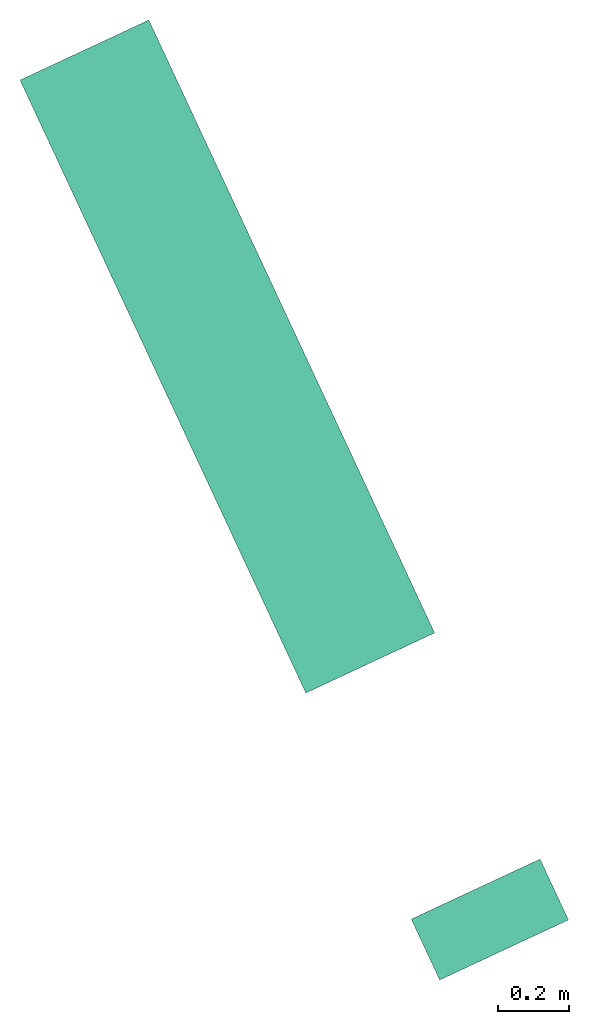
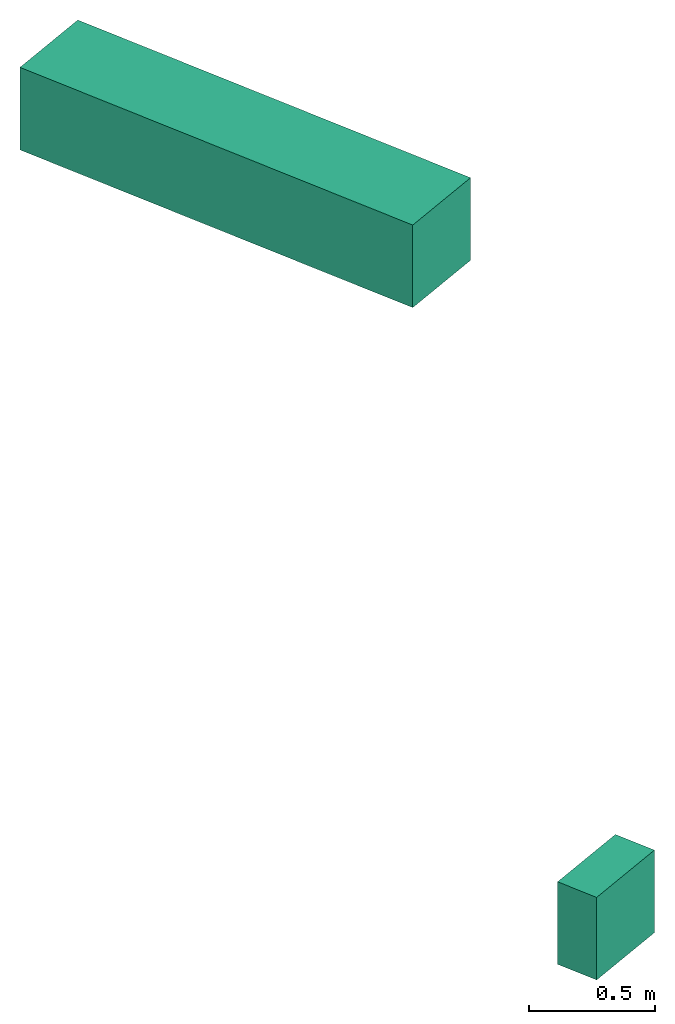
# One storey: 2 flow segments.
"""IFC2X3 building model written with IfcOpenShell, lengths in metres."""

import ifcopenshell
import ifcopenshell.guid

model = None  # the IFC model being written
_history = None  # IfcOwnerHistory: only IFC2X3 demands one
_inside = {}  # id of a spatial element -> (the spatial element, [elements in it])
_under = {}  # id of a project, library or spatial element -> (it, [spatial elements below it])
_declared = {}  # id of a project -> (the project, [libraries it declares])
_typed = {}  # id of a type object -> (the type object, [elements of that type])
_made_of = {}  # id of a material, layer set ... -> (it, [elements and type objects made of it])


def new_model(schema):
    """Start an empty IFC model of exactly this schema.

    Asked for "IFC4X3", IfcOpenShell would pick the latest addendum, in which some entities
    have other attributes; the version numbers below select the first issue.
    IFC2X3 requires an IfcOwnerHistory on every rooted entity: one is made here for all.
    """
    global model, _history
    if schema == "IFC4X3":
        model = ifcopenshell.file(schema_version=(4, 3, 0, 0))
    else:
        model = ifcopenshell.file(schema=schema)
    _inside.clear()
    _under.clear()
    _declared.clear()
    _typed.clear()
    _made_of.clear()
    _history = None
    if model.schema == "IFC2X3":
        org = make("IfcOrganization", Name="unknown")
        user = make(
            "IfcPersonAndOrganization",
            ThePerson=make("IfcPerson", FamilyName="unknown"),
            TheOrganization=org,
        )
        app = make(
            "IfcApplication",
            ApplicationDeveloper=org,
            Version="unknown",
            ApplicationFullName="unknown",
            ApplicationIdentifier="unknown",
        )
        _history = make(
            "IfcOwnerHistory",
            OwningUser=user,
            OwningApplication=app,
            ChangeAction="ADDED",
            CreationDate=0,
        )
    return model


def make(cls, **values):
    """One entity of the class cls with the attributes given. An attribute that is None is left unset."""
    return model.create_entity(
        cls, **{name: value for name, value in values.items() if value is not None}
    )


def entity(cls, *values):
    """Any entity or typed value of the class cls, its attributes in the order of the schema. None: left unset."""
    e = model.create_entity(cls)
    for i, value in enumerate(values):
        if value is not None:
            e[i] = value
    return e


def rooted(cls, **values):
    """An entity with a GlobalId (a new one), such as an element, a storey or a relation."""
    return make(cls, GlobalId=ifcopenshell.guid.new(), OwnerHistory=_history, **values)


def si_unit(unit_type, name, prefix=None):
    """IfcSIUnit, for example si_unit("LENGTHUNIT", "METRE", prefix="MILLI")."""
    return make("IfcSIUnit", UnitType=unit_type, Prefix=prefix, Name=name)


def converted_unit(unit_type, name, factor, base, dimensions=None, offset=None):
    """IfcConversionBasedUnit, such as the inch: factor (a typed value) times the base unit."""
    return make(
        "IfcConversionBasedUnit"
        if offset is None
        else "IfcConversionBasedUnitWithOffset",
        ConversionOffset=offset,
        Dimensions=None
        if dimensions is None
        else entity("IfcDimensionalExponents", *dimensions),
        UnitType=unit_type,
        Name=name,
        ConversionFactor=make(
            "IfcMeasureWithUnit", ValueComponent=factor, UnitComponent=base
        ),
    )


def derived_unit(unit_type, elements):
    """IfcDerivedUnit: a product of units, each with its exponent."""
    return make(
        "IfcDerivedUnit",
        Elements=[
            make("IfcDerivedUnitElement", Unit=unit, Exponent=power)
            for unit, power in elements
        ],
        UnitType=unit_type,
    )


def assignment(units):
    """IfcUnitAssignment: the units of a project."""
    return None if units is None else make("IfcUnitAssignment", Units=units)


def point(xyz):
    """IfcCartesianPoint."""
    return None if xyz is None else make("IfcCartesianPoint", Coordinates=xyz)


def direction(xyz):
    """IfcDirection."""
    return None if xyz is None else make("IfcDirection", DirectionRatios=xyz)


def frame(location, z_axis=None, x_axis=None):
    """IfcAxis2Placement3D, a coordinate frame: its origin and axes. An axis left out is left unset."""
    return make(
        "IfcAxis2Placement3D",
        Location=point(location),
        Axis=direction(z_axis),
        RefDirection=direction(x_axis),
    )


def frame_2d(location, x_axis=None):
    """IfcAxis2Placement2D, a coordinate frame in the plane: its origin and x axis."""
    return make(
        "IfcAxis2Placement2D", Location=point(location), RefDirection=direction(x_axis)
    )


def origin():
    """The frame at (0, 0, 0) with its axes left unset."""
    return frame((0.0, 0.0, 0.0))


def place(relative_to, where):
    """IfcLocalPlacement: puts the frame where relative to a parent placement (None: the world)."""
    return make(
        "IfcLocalPlacement", PlacementRelTo=relative_to, RelativePlacement=where
    )


def context(
    kind, dimensions, precision=None, world=None, true_north=None, identifier=None
):
    """IfcGeometricRepresentationContext, for example the 3D "Model" context."""
    return make(
        "IfcGeometricRepresentationContext",
        ContextIdentifier=identifier,
        ContextType=kind,
        CoordinateSpaceDimension=dimensions,
        Precision=precision,
        WorldCoordinateSystem=world,
        TrueNorth=true_north,
    )


def subcontext(parent, identifier, kind, view, scale=None):
    """IfcGeometricRepresentationSubContext, for example "Body" below "Model"."""
    return make(
        "IfcGeometricRepresentationSubContext",
        ContextIdentifier=identifier,
        ContextType=kind,
        ParentContext=parent,
        TargetScale=scale,
        TargetView=view,
    )


def project(units=None, contexts=None):
    """IfcProject with its units and contexts."""
    return rooted(
        "IfcProject",
        Name="project",
        RepresentationContexts=contexts,
        UnitsInContext=assignment(units),
    )


def spatial(cls, under=None, at=None, **own):
    """A site, building, storey or space (cls), placed at a placement, below another one or the project."""
    s = rooted(cls, ObjectPlacement=at, **own)
    if under is not None:
        _under.setdefault(under.id(), (under, []))[1].append(s)
    return s


def profile(cls, at=None, kind="AREA", **sizes):
    """A parametric profile (cls). Its sizes go by their IFC names, for example OverallWidth=200.0."""
    return make(cls, ProfileType=kind, Position=at, **sizes)


def rectangle(**sizes):
    """IfcRectangleProfileDef."""
    return profile("IfcRectangleProfileDef", **sizes)


def extrude(swept, where, along, depth):
    """IfcExtrudedAreaSolid: the profile swept, set in the frame where, extruded along a direction by depth."""
    return make(
        "IfcExtrudedAreaSolid",
        SweptArea=swept,
        Position=where,
        ExtrudedDirection=direction(along),
        Depth=depth,
    )


def shape(context_of_items, identifier, shape_type, items):
    """IfcShapeRepresentation: the items that make up one representation, for example the "Body"."""
    return make(
        "IfcShapeRepresentation",
        ContextOfItems=context_of_items,
        RepresentationIdentifier=identifier,
        RepresentationType=shape_type,
        Items=items,
    )


def made_of(thing, what):
    """Note that an element or type object is made of a material, layer set ...; save() writes the relation."""
    if what is not None:
        _made_of.setdefault(what.id(), (what, []))[1].append(thing)
    return thing


def type_object(cls, material=None, **own):
    """A type object (cls), such as IfcWallType, which elements share."""
    return made_of(rooted(cls, **own), material)


def element(
    cls,
    number,
    at=None,
    inside=None,
    cuts=None,
    type_object=None,
    material=None,
    context=None,
    identifier="Body",
    shape_type=None,
    held_by="IfcProductDefinitionShape",
    body=None,
    shapes=None,
    **own,
):
    """One element of the class cls, such as IfcWall. Its Tag is "e" and its number.

    at: its placement. inside: the storey or other place that contains it. cuts: it is an
    opening in that element (IfcRelVoidsElement). A single representation is given by context,
    identifier, shape_type and body (its items); several are given by shapes. held_by: the class
    of the entity that holds the representations. save() writes the other relations.
    """
    e = rooted(cls, Tag="e%d" % number, ObjectPlacement=at, **own)
    if body is not None:
        shapes = [shape(context, identifier, shape_type, body)]
    if shapes is not None:
        e.Representation = make(held_by, Representations=shapes)
    if inside is not None:
        _inside.setdefault(inside.id(), (inside, []))[1].append(e)
    if cuts is not None:
        rooted(
            "IfcRelVoidsElement", RelatingBuildingElement=cuts, RelatedOpeningElement=e
        )
    if type_object is not None:
        _typed.setdefault(type_object.id(), (type_object, []))[1].append(e)
    return made_of(e, material)


def aggregate(whole, parts):
    """IfcRelAggregates: a whole, such as a stair, and the parts it consists of."""
    return rooted("IfcRelAggregates", RelatingObject=whole, RelatedObjects=parts)


def save(model, path):
    """Write the relations noted so far, then the file.

    IfcRelAggregates (storeys below a building ...), IfcRelContainedInSpatialStructure (elements
    in a storey), IfcRelDefinesByType, IfcRelAssociatesMaterial and IfcRelDeclares: one each for
    every whole, place, type object, material and project.
    """
    for whole, parts in _under.values():
        aggregate(whole, parts)
    for where, things in _inside.values():
        rooted(
            "IfcRelContainedInSpatialStructure",
            RelatedElements=things,
            RelatingStructure=where,
        )
    for kind, things in _typed.values():
        rooted("IfcRelDefinesByType", RelatedObjects=things, RelatingType=kind)
    for what, things in _made_of.values():
        rooted("IfcRelAssociatesMaterial", RelatedObjects=things, RelatingMaterial=what)
    for by, libraries in _declared.values():
        rooted("IfcRelDeclares", RelatingContext=by, RelatedDefinitions=libraries)
    model.write(path)


model = new_model("IFC2X3")

# Units and contexts
model_context = context("Model", 3, precision=1e-05, world=origin(), true_north=direction((6.12303176911189e-17, 1.0)))
body_context = subcontext(model_context, "Body", "Model", "MODEL_VIEW")
ifc_project = project(units=[si_unit("LENGTHUNIT", "METRE"), si_unit("AREAUNIT", "SQUARE_METRE"), si_unit("VOLUMEUNIT", "CUBIC_METRE"), converted_unit("PLANEANGLEUNIT", "DEGREE", entity("IfcRatioMeasure", 0.0174532925199433), si_unit("PLANEANGLEUNIT", "RADIAN"), dimensions=[0, 0, 0, 0, 0, 0, 0]), si_unit("MASSUNIT", "GRAM", prefix="KILO"), derived_unit("MASSDENSITYUNIT", [(si_unit("MASSUNIT", "GRAM", prefix="KILO"), 1), (si_unit("LENGTHUNIT", "METRE"), -3)]), si_unit("TIMEUNIT", "SECOND"), si_unit("FREQUENCYUNIT", "HERTZ"), si_unit("THERMODYNAMICTEMPERATUREUNIT", "DEGREE_CELSIUS"), derived_unit("THERMALTRANSMITTANCEUNIT", [(si_unit("MASSUNIT", "GRAM", prefix="KILO"), 1), (si_unit("THERMODYNAMICTEMPERATUREUNIT", "KELVIN"), -1), (si_unit("TIMEUNIT", "SECOND"), -3)]), derived_unit("VOLUMETRICFLOWRATEUNIT", [(si_unit("LENGTHUNIT", "METRE"), 3), (si_unit("TIMEUNIT", "SECOND"), -1)]), si_unit("ELECTRICCURRENTUNIT", "AMPERE"), si_unit("ELECTRICVOLTAGEUNIT", "VOLT"), si_unit("POWERUNIT", "WATT"), si_unit("FORCEUNIT", "NEWTON", prefix="KILO"), si_unit("ILLUMINANCEUNIT", "LUX"), si_unit("LUMINOUSFLUXUNIT", "LUMEN"), si_unit("LUMINOUSINTENSITYUNIT", "CANDELA"), derived_unit("USERDEFINED", [(si_unit("MASSUNIT", "GRAM", prefix="KILO"), -1), (si_unit("LENGTHUNIT", "METRE"), -2), (si_unit("TIMEUNIT", "SECOND"), 3), (si_unit("LUMINOUSFLUXUNIT", "LUMEN"), 1)]), derived_unit("LINEARVELOCITYUNIT", [(si_unit("LENGTHUNIT", "METRE"), 1), (si_unit("TIMEUNIT", "SECOND"), -1)]), si_unit("PRESSUREUNIT", "PASCAL"), derived_unit("USERDEFINED", [(si_unit("LENGTHUNIT", "METRE"), -2), (si_unit("MASSUNIT", "GRAM", prefix="KILO"), 1), (si_unit("TIMEUNIT", "SECOND"), -2)])], contexts=[model_context])

# Site, building, storey
site_placement = place(None, frame((-27.6339874998918, 64.4092442595216, 0.0), z_axis=(0.0, 0.0, 1.0), x_axis=(-0.422618261740703, 0.906307787036648, 0.0)))
site = spatial("IfcSite", under=ifc_project, at=site_placement, CompositionType="ELEMENT")
building_placement = place(site_placement, origin())
building = spatial("IfcBuilding", under=site, at=building_placement, CompositionType="ELEMENT")
storey_placement = place(building_placement, origin())
storey = spatial("IfcBuildingStorey", under=building, at=storey_placement, CompositionType="ELEMENT", Elevation=0.0)

# Flow segments
distribution_element_type = type_object("IfcDistributionElementType", Name="Gaine rectangulaire:CVC_27_26_Gaine rectangulaire")
flow_segment_1_placement = place(storey_placement, origin())
element("IfcFlowSegment", 1, at=flow_segment_1_placement, inside=storey, type_object=distribution_element_type, Name="Gaine rectangulaire:27_26_Gaine rectangulaire", ObjectType="Gaine rectangulaire:CVC_27_26_Gaine rectangulaire", context=body_context, shape_type="SweptSolid", body=[
    extrude(rectangle(XDim=1.90302525316942, YDim=0.4, at=frame_2d((1.11022302462516e-15, 0.0), x_axis=(1.0, 0.0))), frame((-14.8100113192433, 14.1713365649654, 3.0)), (0.0, 0.0, 1.0), 0.4),
])
flow_segment_2_placement = place(storey_placement, origin())
element("IfcFlowSegment", 2, at=flow_segment_2_placement, inside=storey, type_object=distribution_element_type, Name="Gaine rectangulaire:27_26_Gaine rectangulaire", ObjectType="Gaine rectangulaire:CVC_27_26_Gaine rectangulaire", context=body_context, shape_type="SweptSolid", body=[
    extrude(rectangle(XDim=0.189, YDim=0.4, at=frame_2d((0.0, 1.08246744900953e-15), x_axis=(1.0, 0.0))), frame((-16.558023945828, 14.1713391870442, 0.1), z_axis=(0.0, 0.0, 1.0), x_axis=(-1.0, 0.0, 0.0)), (0.0, 0.0, 1.0), 0.4),
])

save(model, "model.ifc")
